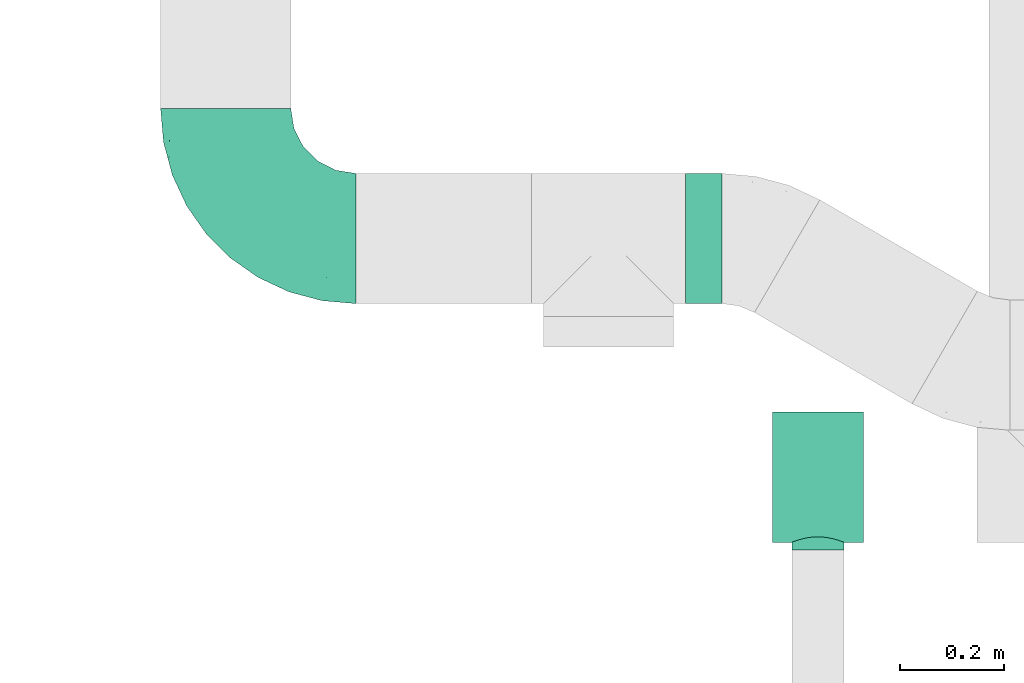
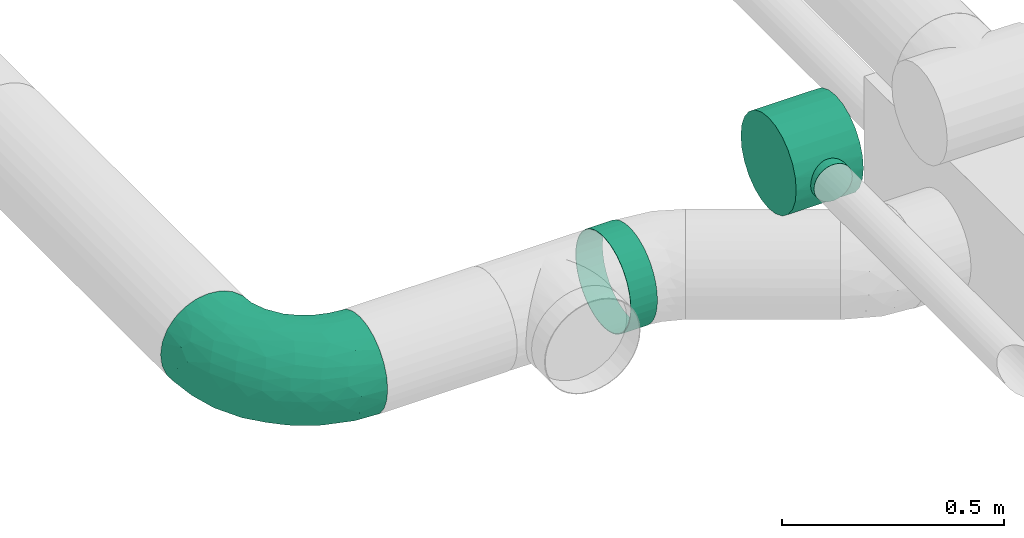
# One storey, part 17 of 91: 2 flow fittings, 1 flow segment.
"""IFC2X3 building model written with IfcOpenShell, lengths in millimetres."""

from ifc_helpers import new_model, entity, si_unit, converted_unit, derived_unit, direction, frame, origin_with_axes, origin_2d_with_axis, place, context, subcontext, project, spatial, hollow_circle, extrude, open_shell, surface_model, source, transform, mapped, material, layer, layer_set, layer_usage, type_object, element, save


model = new_model("IFC2X3")

# Units and contexts
model_context = context("Model", 3, precision=1e-05, world=origin_with_axes(), true_north=direction((0.0, 1.0)))
body_context = subcontext(model_context, "Body", "Model", "MODEL_VIEW")
ifc_project = project(units=[si_unit("AREAUNIT", "SQUARE_METRE"), si_unit("VOLUMEUNIT", "CUBIC_METRE", prefix="DECI"), si_unit("TIMEUNIT", "SECOND"), si_unit("THERMODYNAMICTEMPERATUREUNIT", "DEGREE_CELSIUS"), si_unit("PRESSUREUNIT", "PASCAL"), si_unit("MASSUNIT", "GRAM", prefix="KILO"), si_unit("LENGTHUNIT", "METRE", prefix="MILLI"), si_unit("POWERUNIT", "WATT"), si_unit("ELECTRICCURRENTUNIT", "AMPERE"), si_unit("ELECTRICVOLTAGEUNIT", "VOLT"), derived_unit("VOLUMETRICFLOWRATEUNIT", [(si_unit("VOLUMEUNIT", "CUBIC_METRE", prefix="DECI"), 1), (si_unit("TIMEUNIT", "SECOND"), -1)]), derived_unit("LINEARVELOCITYUNIT", [(si_unit("LENGTHUNIT", "METRE"), 1), (si_unit("TIMEUNIT", "SECOND"), -1)]), derived_unit("MASSDENSITYUNIT", [(si_unit("MASSUNIT", "GRAM", prefix="KILO"), 1), (si_unit("VOLUMEUNIT", "CUBIC_METRE"), -1)]), converted_unit("PLANEANGLEUNIT", "DEGREE", entity("IfcRatioMeasure", 0.01745), si_unit("PLANEANGLEUNIT", "RADIAN"), dimensions=[0, 0, 0, 0, 0, 0, 0])], contexts=[model_context])

# Site, building, storey
site_placement = place(None, origin_with_axes())
site = spatial("IfcSite", under=ifc_project, at=site_placement, CompositionType="ELEMENT")
building_placement = place(site_placement, origin_with_axes())
building = spatial("IfcBuilding", under=site, at=building_placement, Name="mc-building", CompositionType="ELEMENT")
storey_placement = place(building_placement, frame((0.0, 0.0, 8700.0), z_axis=(0.0, 0.0, 1.0), x_axis=(1.0, 0.0, 0.0)))
storey = spatial("IfcBuildingStorey", under=building, at=storey_placement, CompositionType="ELEMENT", Elevation=8700.0)

# Flow fittings
duct_fitting_type_1 = type_object("IfcDuctFittingType", Name="BU", PredefinedType="BEND")
shared_shape_1 = source(origin_with_axes(), body_context, "Body", "SurfaceModel", [
    surface_model("IfcShellBasedSurfaceModel", [(-250.0, 0.0, -125.0), (-250.0, -32.35238, -120.74073), (-250.0, 32.35238, -120.74073), (-250.0, 120.74073, 32.35238), (-250.0, 62.5, -108.25318), (-250.0, 108.25318, -62.5), (-250.0, 88.38835, -88.38835), (-250.0, -125.0, 0.0), (-250.0, -120.74073, 32.35238), (-250.0, -88.38835, -88.38835), (-250.0, -62.5, -108.25318), (-250.0, -120.74073, -32.35238), (-250.0, -108.25318, -62.5), (-250.0, 120.74073, -32.35238), (-250.0, 108.25318, 62.5), (-250.0, 88.38835, 88.38835), (-250.0, 32.35238, 120.74073), (-250.0, 62.5, 108.25318), (-250.0, 0.0, 125.0), (-250.0, -108.25318, 62.5), (-250.0, -88.38835, 88.38835), (-250.0, -32.35238, 120.74073), (-250.0, -62.5, 108.25318), (-250.0, 125.0, 0.0), (-32.35238, 250.0, -120.74073), (-125.0, 250.0, 0.0), (0.0, 250.0, -125.0), (-62.5, 250.0, -108.25318), (-88.38835, 250.0, -88.38835), (-108.25318, 250.0, -62.5), (88.38835, 250.0, -88.38835), (120.74073, 250.0, 32.35238), (62.5, 250.0, -108.25318), (32.35238, 250.0, -120.74073), (108.25318, 250.0, -62.5), (120.74073, 250.0, -32.35238), (125.0, 250.0, 0.0), (-120.74073, 250.0, -32.35238), (-120.74073, 250.0, 32.35238), (-108.25318, 250.0, 62.5), (-88.38835, 250.0, 88.38835), (-32.35238, 250.0, 120.74073), (-62.5, 250.0, 108.25318), (62.5, 250.0, 108.25318), (108.25318, 250.0, 62.5), (88.38835, 250.0, 88.38835), (32.35238, 250.0, 120.74073), (0.0, 250.0, 125.0), (-117.1466, 118.31037, 107.99909), (-96.3976, 96.3976, 120.62713), (-81.83105, 144.33246, 113.94821), (-194.36977, 6.26802, 125.0), (-210.4208, 30.62363, 122.03104), (-141.52906, 24.75778, 125.0), (-170.49386, 38.98103, 122.57548), (-119.6899, 216.62967, 47.83543), (-24.75778, 141.52906, 125.0), (-58.72535, 129.81418, 122.65468), (-54.54213, 94.12755, 125.0), (-164.16498, 126.25836, 75.79028), (-183.25942, 133.03051, 48.20921), (-192.36733, 110.61415, 76.09518), (-129.81418, 58.72535, 122.65468), (-136.01097, 136.01098, 87.97963), (-106.86909, 152.6368, 98.55189), (-123.74113, 163.86567, 78.64582), (-94.12755, 54.54213, 125.0), (-55.07783, 196.37292, 115.48494), (-30.62363, 210.4208, 122.03104), (-80.06444, 213.05689, 99.16916), (-216.62967, 119.68991, 47.83543), (-223.32127, 101.54736, 76.09518), (-226.00176, 125.30303, 22.18937), (-213.05689, 80.06444, 99.16916), (-38.98103, 170.49388, 122.57548), (-167.42296, 153.3147, 23.08194), (-162.69986, 162.69986, 0.0), (-176.52685, 148.87287, 0.0), (-131.11793, 211.37287, 0.0), (-131.91505, 201.08762, 26.37495), (-125.30889, 225.96459, 22.19643), (-196.37292, 55.07783, 115.48495), (-167.53374, 99.7969, 97.1574), (-144.33245, 81.83105, 113.94821), (-82.81251, 177.89548, 104.93319), (-133.0305, 183.25942, 48.20921), (-110.61415, 192.36733, 76.09518), (-101.54736, 223.32127, 76.09518), (-150.35937, 170.37352, 25.11258), (-148.87287, 176.52685, 0.0), (-188.58367, 138.9352, 21.795), (-139.99541, 193.94986, 0.0), (-144.89628, 149.85264, 68.09613), (-6.26802, 194.36977, 125.0), (-155.58398, 155.58398, 45.37002), (-211.37287, 131.11793, 0.0), (-136.01097, 136.01098, -87.97963), (-152.6368, 106.86909, -98.55189), (-163.86567, 123.74113, -78.64581), (-225.96459, 125.30889, -22.19643), (-192.36733, 110.61415, -76.09518), (-223.32127, 101.54736, -76.09518), (-216.62967, 119.68991, -47.83543), (-118.31037, 117.14661, -107.99909), (-170.37352, 150.35937, -25.11258), (-183.25942, 133.03051, -48.20921), (-119.6899, 216.62967, -47.83543), (-133.0305, 183.25942, -48.20921), (-138.9352, 188.58369, -21.795), (-213.05689, 80.06444, -99.16916), (-196.37292, 55.07783, -115.48495), (-201.08762, 131.91505, -26.37495), (-193.94986, 139.99541, 0.0), (-129.81418, 58.72535, -122.65468), (-170.49386, 38.98103, -122.57548), (-144.33245, 81.83105, -113.94821), (-210.4208, 30.62363, -122.03104), (-126.25836, 164.16498, -75.79028), (-99.7969, 167.53376, -97.1574), (-81.83105, 144.33246, -113.94821), (-96.3976, 96.3976, -120.62713), (-55.07783, 196.37292, -115.48494), (-30.62363, 210.4208, -122.03104), (-38.98103, 170.49388, -122.57548), (-177.89548, 82.81251, -104.93319), (-153.3147, 167.42296, -23.08194), (-94.12755, 54.54213, -125.0), (-141.52906, 24.75778, -125.0), (-101.54736, 223.32127, -76.09518), (-80.06444, 213.05689, -99.16916), (-125.30303, 226.00176, -22.18937), (-54.54213, 94.12755, -125.0), (-24.75778, 141.52906, -125.0), (-58.72535, 129.81418, -122.65468), (-110.61415, 192.36733, -76.09518), (-6.26802, 194.36977, -125.0), (-149.85264, 144.89629, -68.09613), (-194.36977, 6.26802, -125.0), (-155.58398, 155.58398, -45.37002), (-193.89957, -74.54276, -96.57977), (-62.5, -74.75953, 0.0), (-121.74244, -102.38473, 0.0), (-94.73344, -89.12736, -22.37394), (119.30291, 184.88194, 0.0), (109.25277, 157.04874, -31.04738), (-53.59476, 53.59477, -121.8788), (-9.37807, 56.98679, -110.48256), (-81.86678, 3.72743, -115.33626), (-145.59015, -7.38807, -121.8788), (-12.03452, 12.03453, -90.20459), (23.00116, 67.52551, -97.38178), (40.98911, 53.20617, -73.25276), (-159.90694, -102.02588, -52.64847), (81.22573, 100.98341, -53.01017), (92.95193, 171.4026, -72.47744), (107.80964, 186.67175, -52.65074), (13.81192, -13.81192, -21.78849), (8.88806, -8.88806, -46.26498), (55.09242, 37.49634, -28.07964), (-184.88194, -119.30291, 0.0), (87.32054, 94.83884, -30.20715), (49.0818, 42.5299, -51.28061), (-171.40262, -92.95193, -72.47744), (-3.30282, -3.44047, -69.82022), (-100.98341, -81.22573, -53.01016), (37.26667, 8.95465, 0.0), (-8.95465, -37.26667, 0.0), (-37.49634, -55.09242, -28.07964), (46.65178, 188.51647, -113.22824), (-157.04874, -109.25277, -31.04738), (16.88787, 136.38295, -118.40506), (-42.32523, -45.52951, -57.0897), (-69.83191, -18.55522, -101.18597), (-150.46416, -40.11916, -111.39103), (-60.46923, -37.78604, -81.71663), (74.54276, 193.89959, -96.57977), (102.38473, 121.74244, 0.0), (74.75953, 62.5, 0.0), (36.31281, 122.56516, -107.73314), (-124.37151, -58.88278, -93.06207), (-111.05914, -71.02736, -75.26007), (71.09889, 111.35886, -75.33067), (58.88278, 124.37151, -93.06207), (-157.04874, -109.25277, 31.04738), (-53.20616, -40.9891, 73.25276), (3.44048, 3.30283, 69.82022), (-12.03452, 12.03453, 90.20459), (55.09242, 37.49634, 28.07964), (-37.49634, -55.09242, 28.07964), (-94.83884, -87.32054, 30.20715), (-67.52551, -23.00116, 97.38178), (-186.67175, -107.80965, 52.65074), (7.38807, 145.59015, 121.8788), (-42.5299, -49.0818, 51.28061), (-53.59476, 53.59477, 121.8788), (-56.98679, 9.37808, 110.48256), (-3.72743, 81.86679, 115.33626), (13.81192, -13.81192, 21.78849), (-188.51647, -46.65178, 113.22824), (-136.38295, -16.88787, 118.40506), (-171.40262, -92.95193, 72.47744), (40.11916, 150.46417, 111.39103), (-122.56517, -36.31281, 107.73314), (92.95193, 171.4026, 72.47744), (37.78605, 60.46924, 81.71663), (-193.89957, -74.54276, 96.57977), (8.88806, -8.88806, 46.26498), (109.25277, 157.04874, 31.04738), (89.12736, 94.73344, 22.37394), (18.55523, 69.83191, 101.18597), (-100.98341, -81.22573, 53.01016), (102.02588, 159.90694, 52.64847), (81.22573, 100.98341, 53.01017), (74.54276, 193.89959, 96.57977), (45.52951, 42.32523, 57.0897), (58.88278, 124.37151, 93.06207), (-111.35886, -71.09889, 75.33067), (-124.37151, -58.88278, 93.06207), (71.02736, 111.05915, 75.26008)], [open_shell([[[0, 1, 2]], [[2, 3, 4]], [[5, 6, 3]], [[3, 6, 4]], [[2, 7, 8]], [[9, 7, 10]], [[2, 1, 10]], [[11, 7, 12]], [[9, 12, 7]], [[10, 7, 2]], [[13, 5, 3]], [[14, 3, 2]], [[14, 2, 15]], [[2, 16, 17]], [[17, 15, 2]], [[16, 2, 18]], [[19, 20, 2]], [[2, 8, 19]], [[21, 18, 22]], [[20, 22, 18]], [[18, 2, 20]], [[23, 13, 3]], [[24, 25, 26]], [[27, 25, 24]], [[25, 28, 29]], [[27, 28, 25]], [[30, 26, 31]], [[26, 30, 32]], [[32, 33, 26]], [[30, 31, 34]], [[35, 34, 31]], [[35, 31, 36]], [[37, 25, 29]], [[38, 39, 26]], [[39, 40, 26]], [[41, 26, 42]], [[26, 40, 42]], [[43, 26, 41]], [[44, 31, 26]], [[45, 44, 26]], [[41, 46, 43]], [[45, 26, 43]], [[46, 41, 47]], [[38, 26, 25]], [[48, 49, 50]], [[18, 51, 52]], [[51, 53, 54]], [[39, 38, 55]], [[56, 57, 58]], [[59, 60, 61]], [[57, 49, 58]], [[54, 53, 62]], [[63, 64, 65]], [[62, 53, 66]], [[67, 68, 41]], [[42, 40, 69]], [[70, 14, 71]], [[3, 72, 23]], [[70, 3, 14]], [[73, 15, 17]], [[57, 74, 50]], [[14, 15, 71]], [[75, 76, 77]], [[42, 69, 67]], [[58, 49, 66]], [[78, 79, 80]], [[16, 81, 17]], [[82, 73, 81]], [[74, 68, 67]], [[49, 48, 83]], [[81, 52, 54]], [[42, 67, 41]], [[41, 68, 47]], [[60, 70, 61]], [[72, 3, 70]], [[84, 67, 69]], [[85, 86, 55]], [[87, 40, 39]], [[88, 89, 76]], [[64, 63, 48]], [[59, 82, 63]], [[17, 81, 73]], [[25, 78, 80]], [[86, 87, 55]], [[70, 60, 90]], [[62, 49, 83]], [[82, 81, 83]], [[60, 75, 90]], [[71, 73, 61]], [[79, 91, 88]], [[87, 69, 40]], [[86, 64, 84]], [[92, 59, 63]], [[76, 75, 88]], [[78, 91, 79]], [[65, 92, 63]], [[49, 62, 66]], [[54, 83, 81]], [[83, 54, 62]], [[81, 16, 52]], [[74, 57, 56]], [[49, 57, 50]], [[93, 74, 56]], [[50, 74, 67]], [[18, 52, 16]], [[51, 54, 52]], [[74, 93, 68]], [[47, 68, 93]], [[73, 71, 15]], [[70, 71, 61]], [[55, 87, 39]], [[69, 87, 86]], [[64, 48, 50]], [[48, 63, 82]], [[84, 64, 50]], [[65, 64, 86]], [[67, 84, 50]], [[86, 84, 69]], [[86, 85, 65]], [[92, 85, 94]], [[85, 92, 65]], [[59, 94, 60]], [[59, 92, 94]], [[82, 59, 61]], [[73, 82, 61]], [[82, 83, 48]], [[94, 88, 75]], [[90, 75, 77]], [[60, 94, 75]], [[77, 95, 90]], [[90, 95, 72]], [[94, 85, 88]], [[88, 91, 89]], [[79, 88, 85]], [[85, 55, 79]], [[80, 79, 55]], [[55, 38, 80]], [[25, 80, 38]], [[90, 72, 70]], [[23, 72, 95]], [[96, 97, 98]], [[23, 95, 99]], [[100, 101, 102]], [[97, 96, 103]], [[104, 77, 76]], [[100, 102, 105]], [[5, 13, 102]], [[101, 6, 5]], [[106, 107, 108]], [[4, 109, 110]], [[111, 112, 104]], [[113, 114, 115]], [[4, 110, 2]], [[2, 116, 0]], [[117, 118, 96]], [[114, 116, 110]], [[103, 119, 120]], [[121, 122, 123]], [[110, 109, 124]], [[125, 76, 89]], [[126, 127, 113]], [[100, 97, 124]], [[128, 29, 28]], [[4, 6, 109]], [[29, 106, 37]], [[129, 28, 27]], [[24, 121, 27]], [[106, 29, 128]], [[37, 130, 25]], [[110, 116, 2]], [[95, 111, 99]], [[118, 129, 121]], [[27, 121, 129]], [[126, 120, 131]], [[123, 132, 133]], [[125, 108, 107]], [[117, 107, 134]], [[103, 120, 115]], [[26, 135, 122]], [[135, 132, 123]], [[132, 131, 133]], [[113, 120, 126]], [[130, 37, 106]], [[133, 120, 119]], [[101, 109, 6]], [[107, 106, 134]], [[118, 121, 119]], [[128, 129, 134]], [[95, 112, 111]], [[98, 136, 96]], [[136, 117, 96]], [[76, 125, 104]], [[114, 113, 127]], [[120, 113, 115]], [[137, 114, 127]], [[115, 114, 110]], [[120, 133, 131]], [[123, 119, 121]], [[119, 123, 133]], [[121, 24, 122]], [[114, 137, 116]], [[0, 116, 137]], [[26, 122, 24]], [[135, 123, 122]], [[102, 101, 5]], [[109, 101, 100]], [[129, 128, 28]], [[106, 128, 134]], [[97, 103, 115]], [[103, 96, 118]], [[124, 97, 115]], [[98, 97, 100]], [[110, 124, 115]], [[100, 124, 109]], [[100, 105, 98]], [[136, 105, 138]], [[105, 136, 98]], [[117, 138, 107]], [[117, 136, 138]], [[118, 117, 134]], [[129, 118, 134]], [[118, 119, 103]], [[138, 104, 125]], [[108, 125, 89]], [[107, 138, 125]], [[89, 78, 108]], [[108, 78, 130]], [[138, 105, 104]], [[104, 112, 77]], [[111, 104, 105]], [[105, 102, 111]], [[99, 111, 102]], [[102, 13, 99]], [[23, 99, 13]], [[108, 130, 106]], [[25, 130, 78]], [[139, 9, 10]], [[140, 141, 142]], [[35, 143, 144]], [[127, 126, 145]], [[126, 131, 145]], [[145, 146, 147]], [[137, 148, 0]], [[149, 150, 151]], [[127, 145, 148]], [[152, 11, 12]], [[153, 154, 155]], [[156, 157, 158]], [[159, 7, 11]], [[144, 160, 153]], [[161, 158, 157]], [[152, 12, 162]], [[151, 161, 163]], [[152, 162, 164]], [[156, 165, 166]], [[142, 164, 167]], [[168, 33, 32]], [[141, 159, 169]], [[142, 141, 169]], [[127, 148, 137]], [[132, 170, 145]], [[171, 167, 164]], [[135, 170, 132]], [[0, 148, 1]], [[147, 172, 173]], [[170, 135, 33]], [[168, 170, 33]], [[132, 145, 131]], [[173, 148, 147]], [[1, 148, 173]], [[149, 163, 174]], [[33, 135, 26]], [[146, 145, 170]], [[34, 155, 154]], [[30, 175, 32]], [[156, 166, 167]], [[160, 176, 177]], [[149, 174, 172]], [[160, 177, 158]], [[154, 30, 34]], [[162, 12, 9]], [[36, 143, 35]], [[165, 158, 177]], [[144, 143, 176]], [[35, 144, 155]], [[140, 167, 166]], [[146, 178, 150]], [[147, 148, 145]], [[159, 11, 169]], [[151, 163, 149]], [[178, 170, 168]], [[172, 146, 149]], [[139, 173, 179]], [[1, 173, 10]], [[139, 162, 9]], [[180, 179, 174]], [[181, 153, 151]], [[175, 154, 182]], [[175, 168, 32]], [[168, 175, 178]], [[150, 178, 182]], [[146, 170, 178]], [[182, 154, 181]], [[146, 150, 149]], [[182, 151, 150]], [[153, 160, 161]], [[157, 156, 167]], [[165, 156, 158]], [[157, 171, 163]], [[174, 179, 172]], [[171, 174, 163]], [[179, 180, 162]], [[173, 172, 179]], [[146, 172, 147]], [[167, 171, 157]], [[171, 164, 180]], [[171, 180, 174]], [[164, 162, 180]], [[154, 175, 30]], [[175, 182, 178]], [[173, 139, 10]], [[162, 139, 179]], [[164, 142, 169]], [[140, 142, 167]], [[163, 161, 157]], [[151, 153, 161]], [[176, 160, 144]], [[161, 160, 158]], [[164, 169, 152]], [[152, 169, 11]], [[35, 155, 34]], [[153, 155, 144]], [[153, 181, 154]], [[151, 182, 181]], [[183, 159, 141]], [[159, 8, 7]], [[184, 185, 186]], [[187, 165, 177]], [[140, 188, 189]], [[186, 190, 184]], [[183, 191, 8]], [[56, 192, 93]], [[185, 184, 193]], [[189, 141, 140]], [[194, 195, 196]], [[197, 188, 166]], [[198, 199, 21]], [[191, 200, 19]], [[46, 192, 201]], [[195, 202, 190]], [[203, 44, 45]], [[51, 18, 21]], [[198, 21, 22]], [[199, 53, 51]], [[21, 199, 51]], [[53, 194, 66]], [[196, 192, 194]], [[186, 185, 204]], [[166, 188, 140]], [[200, 20, 19]], [[205, 22, 20]], [[188, 197, 206]], [[176, 143, 207]], [[208, 176, 207]], [[143, 36, 31]], [[186, 204, 209]], [[183, 189, 210]], [[203, 211, 44]], [[177, 176, 208]], [[187, 208, 212]], [[187, 197, 165]], [[212, 211, 203]], [[58, 192, 56]], [[194, 58, 66]], [[47, 192, 46]], [[196, 209, 201]], [[211, 31, 44]], [[194, 192, 58]], [[8, 159, 183]], [[93, 192, 47]], [[143, 31, 207]], [[194, 53, 199]], [[45, 43, 213]], [[210, 200, 191]], [[193, 188, 206]], [[196, 201, 192]], [[214, 187, 212]], [[195, 194, 199]], [[202, 199, 198]], [[209, 195, 186]], [[213, 201, 215]], [[46, 201, 43]], [[216, 210, 184]], [[205, 200, 217]], [[213, 203, 45]], [[218, 215, 204]], [[205, 198, 22]], [[198, 205, 202]], [[190, 202, 217]], [[195, 199, 202]], [[217, 200, 216]], [[195, 190, 186]], [[217, 184, 190]], [[210, 189, 193]], [[165, 197, 166]], [[206, 197, 187]], [[206, 214, 185]], [[204, 215, 209]], [[214, 204, 185]], [[215, 218, 203]], [[201, 209, 215]], [[195, 209, 196]], [[187, 214, 206]], [[214, 212, 218]], [[214, 218, 204]], [[212, 203, 218]], [[200, 205, 20]], [[205, 217, 202]], [[201, 213, 43]], [[203, 213, 215]], [[185, 193, 206]], [[184, 210, 193]], [[141, 189, 183]], [[193, 189, 188]], [[212, 208, 207]], [[177, 208, 187]], [[8, 191, 19]], [[210, 191, 183]], [[212, 207, 211]], [[211, 207, 31]], [[210, 216, 200]], [[184, 217, 216]]])]),
])
flow_fitting_1_placement = place(storey_placement, frame((6828.023, 8133.41275, 668.0), z_axis=(0.0, 0.0, 1.0), x_axis=(0.0, -1.0, 0.0)))
element("IfcFlowFitting", 1, at=flow_fitting_1_placement, inside=storey, type_object=duct_fitting_type_1, Name="BU", context=body_context, shape_type="MappedRepresentation", body=[
    mapped(shared_shape_1, transform((0.0, 0.0, 0.0), scale=1.0)),
])
duct_fitting_type_2 = type_object("IfcDuctFittingType", PredefinedType="JUNCTION")
shared_shape_2 = source(origin_with_axes(), body_context, "Body", "SurfaceModel", [
    surface_model("IfcShellBasedSurfaceModel", [(0.0, -140.0, -50.0), (12.94095, -140.0, -48.29629), (-12.94095, -140.0, -48.29629), (-48.29629, -140.0, 12.94095), (-25.0, -140.0, -43.30127), (-35.35534, -140.0, -35.35534), (-43.30127, -140.0, -25.0), (50.0, -140.0, 0.0), (48.29629, -140.0, 12.94095), (35.35534, -140.0, -35.35534), (25.0, -140.0, -43.30127), (48.29629, -140.0, -12.94095), (43.30127, -140.0, -25.0), (-48.29629, -140.0, -12.94095), (-43.30127, -140.0, 25.0), (-35.35534, -140.0, 35.35534), (-25.0, -140.0, 43.30127), (12.94095, -140.0, 48.29629), (-12.94095, -140.0, 48.29629), (43.30127, -140.0, 25.0), (35.35534, -140.0, 35.35534), (25.0, -140.0, 43.30127), (0.0, -140.0, 50.0), (-50.0, -140.0, 0.0), (0.0, -114.56439, 50.0), (-11.23344, -115.11381, 48.72176), (-21.81227, -116.62236, 44.99139), (-31.21528, -118.74087, 39.05901), (-39.0526, -121.03762, 31.2233), (-44.99266, -123.08265, 21.80964), (-48.72466, -124.49535, 11.22084), (-50.0, -125.0, 0.0), (-44.98471, -123.07975, -21.82604), (-39.04056, -121.03374, -31.23835), (-48.72121, -124.494, -11.23581), (-31.2003, -118.73693, -39.07098), (-21.79611, -116.61934, -44.99922), (-11.21877, -115.11239, -48.72514), (0.0, -114.56439, -50.0), (11.23344, -115.11381, -48.72176), (21.81227, -116.62236, -44.99139), (31.21528, -118.74087, -39.05901), (39.0526, -121.03762, -31.2233), (44.99266, -123.08265, -21.80964), (48.72466, -124.49535, -11.22084), (50.0, -125.0, 0.0), (44.99266, -123.08265, 21.80964), (39.0526, -121.03762, 31.2233), (48.72466, -124.49535, 11.22084), (31.21528, -118.74087, 39.05901), (21.81227, -116.62236, 44.99139), (11.23344, -115.11381, 48.72176), (-87.5, 0.0, -125.0), (-87.5, -32.35238, -120.74073), (-87.5, 32.35238, -120.74073), (-87.5, 120.74073, 32.35238), (-87.5, 62.5, -108.25318), (-87.5, 88.38835, -88.38835), (-87.5, 108.25318, -62.5), (-87.5, -125.0, 0.0), (-87.5, -120.74073, 32.35238), (-87.5, -88.38835, -88.38835), (-87.5, -62.5, -108.25318), (-87.5, -120.74073, -32.35238), (-87.5, -108.25318, -62.5), (-87.5, 120.74073, -32.35238), (-87.5, 108.25318, 62.5), (-87.5, 62.5, 108.25318), (-87.5, 32.35238, 120.74073), (-87.5, 88.38835, 88.38835), (-87.5, 0.0, 125.0), (-87.5, -108.25318, 62.5), (-87.5, -88.38835, 88.38835), (-87.5, -32.35238, 120.74073), (-87.5, -62.5, 108.25318), (-87.5, 125.0, 0.0), (87.5, 32.35238, -120.74073), (87.5, 125.0, 0.0), (87.5, 0.0, -125.0), (87.5, 62.5, -108.25318), (87.5, 108.25318, -62.5), (87.5, 88.38835, -88.38835), (87.5, -88.38835, -88.38835), (87.5, -120.74073, 32.35238), (87.5, -62.5, -108.25318), (87.5, -32.35238, -120.74073), (87.5, -108.25318, -62.5), (87.5, -120.74073, -32.35238), (87.5, -125.0, 0.0), (87.5, 120.74073, -32.35238), (87.5, 120.74073, 32.35238), (87.5, 108.25318, 62.5), (87.5, 62.5, 108.25318), (87.5, 32.35238, 120.74073), (87.5, 88.38835, 88.38835), (87.5, -62.5, 108.25318), (87.5, -108.25318, 62.5), (87.5, -88.38835, 88.38835), (87.5, -32.35238, 120.74073), (87.5, 0.0, 125.0), (-87.5, -122.87036, -16.17619), (87.5, -122.87036, -16.17619), (87.5, -122.87036, 16.17619), (-87.5, -122.87036, 16.17619)], [open_shell([[[0, 1, 2]], [[2, 3, 4]], [[5, 3, 6]], [[4, 3, 5]], [[2, 7, 8]], [[9, 7, 10]], [[1, 10, 7]], [[11, 7, 12]], [[9, 12, 7]], [[7, 2, 1]], [[13, 6, 3]], [[14, 3, 2]], [[15, 14, 2]], [[16, 2, 17]], [[16, 15, 2]], [[16, 17, 18]], [[2, 8, 19]], [[2, 19, 20]], [[20, 21, 2]], [[17, 2, 21]], [[17, 22, 18]], [[23, 13, 3]], [[22, 24, 25]], [[18, 25, 26]], [[22, 25, 18]], [[16, 27, 15]], [[16, 18, 26]], [[27, 16, 26]], [[28, 29, 14]], [[30, 31, 23]], [[29, 30, 3]], [[15, 28, 14]], [[3, 14, 29]], [[23, 3, 30]], [[28, 15, 27]], [[32, 33, 6]], [[34, 32, 13]], [[31, 34, 23]], [[23, 34, 13]], [[32, 6, 13]], [[33, 5, 6]], [[4, 35, 36]], [[36, 37, 2]], [[38, 0, 37]], [[5, 35, 4]], [[0, 2, 37]], [[36, 2, 4]], [[35, 5, 33]], [[0, 38, 39]], [[1, 39, 40]], [[0, 39, 1]], [[10, 41, 9]], [[10, 1, 40]], [[41, 10, 40]], [[42, 43, 12]], [[44, 45, 7]], [[43, 44, 11]], [[9, 42, 12]], [[11, 12, 43]], [[7, 11, 44]], [[42, 9, 41]], [[46, 47, 19]], [[48, 46, 8]], [[45, 48, 7]], [[7, 48, 8]], [[46, 19, 8]], [[47, 20, 19]], [[21, 49, 50]], [[50, 51, 17]], [[24, 22, 51]], [[20, 49, 21]], [[17, 21, 50]], [[22, 17, 51]], [[49, 20, 47]], [[52, 53, 54]], [[54, 55, 56]], [[57, 55, 58]], [[56, 55, 57]], [[54, 59, 60]], [[61, 59, 62]], [[54, 53, 62]], [[63, 59, 64]], [[61, 64, 59]], [[62, 59, 54]], [[65, 58, 55]], [[66, 55, 54]], [[67, 66, 54]], [[67, 54, 68]], [[69, 66, 67]], [[70, 68, 54]], [[60, 71, 54]], [[71, 72, 54]], [[73, 70, 74]], [[72, 74, 70]], [[54, 72, 70]], [[75, 65, 55]], [[76, 77, 78]], [[79, 77, 76]], [[80, 77, 81]], [[79, 81, 77]], [[82, 78, 83]], [[78, 84, 85]], [[78, 82, 84]], [[86, 83, 87]], [[86, 82, 83]], [[83, 88, 87]], [[77, 80, 89]], [[90, 91, 78]], [[78, 91, 92]], [[93, 78, 92]], [[92, 91, 94]], [[78, 93, 95]], [[78, 96, 83]], [[97, 96, 78]], [[97, 78, 95]], [[93, 98, 95]], [[93, 99, 98]], [[77, 90, 78]], [[68, 99, 93]], [[67, 93, 92]], [[70, 99, 68]], [[68, 93, 67]], [[92, 69, 67]], [[92, 94, 69]], [[55, 91, 90]], [[75, 90, 77]], [[94, 66, 69]], [[94, 91, 66]], [[66, 91, 55]], [[90, 75, 55]], [[89, 80, 65]], [[77, 89, 75]], [[65, 75, 89]], [[58, 65, 80]], [[80, 57, 58]], [[80, 81, 57]], [[54, 79, 76]], [[52, 76, 78]], [[81, 56, 57]], [[81, 79, 56]], [[56, 79, 54]], [[76, 52, 54]], [[85, 53, 78]], [[84, 62, 85]], [[64, 82, 86]], [[34, 59, 100]], [[39, 38, 86]], [[86, 40, 39]], [[84, 82, 61]], [[64, 86, 38]], [[85, 62, 53]], [[53, 52, 78]], [[37, 36, 64]], [[43, 101, 44]], [[61, 82, 64]], [[36, 63, 64]], [[61, 62, 84]], [[38, 37, 64]], [[41, 87, 42]], [[87, 41, 40]], [[42, 87, 43]], [[88, 45, 44]], [[87, 101, 43]], [[44, 101, 88]], [[63, 33, 32]], [[33, 63, 35]], [[35, 63, 36]], [[100, 63, 32]], [[31, 59, 34]], [[100, 32, 34]], [[87, 40, 86]], [[45, 88, 48]], [[102, 83, 46]], [[46, 83, 47]], [[46, 48, 102]], [[49, 47, 83]], [[83, 50, 49]], [[31, 30, 59]], [[59, 30, 103]], [[28, 27, 60]], [[60, 103, 29]], [[60, 29, 28]], [[27, 26, 60]], [[50, 96, 51]], [[96, 50, 83]], [[24, 51, 96]], [[48, 88, 102]], [[95, 98, 73]], [[74, 97, 95]], [[72, 96, 97]], [[70, 98, 99]], [[25, 24, 71]], [[26, 71, 60]], [[71, 26, 25]], [[96, 71, 24]], [[29, 103, 30]], [[96, 72, 71]], [[97, 74, 72]], [[73, 74, 95]], [[98, 70, 73]]])]),
])
flow_fitting_2_placement = place(storey_placement, frame((7965.12654, 7675.18604, 1214.30701), z_axis=(0.0, 0.0, 1.0), x_axis=(1.0, 0.0, 0.0)))
element("IfcFlowFitting", 2, at=flow_fitting_2_placement, inside=storey, type_object=duct_fitting_type_2, context=body_context, shape_type="MappedRepresentation", body=[
    mapped(shared_shape_2, transform((0.0, 0.0, 0.0), scale=1.0)),
])

# Flow segment
ifc_material = material(Name="FZ1")
ifc_layer = layer(ifc_material, 0.0)
ifc_layer_set = layer_set([ifc_layer], Name="FZ1")
ifc_layer_usage = layer_usage(ifc_layer_set, "AXIS1", "POSITIVE", 0.0)
duct_segment_type = type_object("IfcDuctSegmentType", Name="Safe", PredefinedType="RIGIDSEGMENT")
shared_shape_3 = source(origin_with_axes(), body_context, "Body", "SweptSolid", [
    extrude(hollow_circle(Radius=125.0, WallThickness=2.0, at=origin_2d_with_axis()), frame((0.0, 0.0, 0.0), z_axis=(1.0, 0.0, 0.0), x_axis=(0.0, 1.0, 0.0)), (0.0, 0.0, 1.0), 69.4),
])
flow_segment_placement = place(storey_placement, frame((7711.36286, 8133.41275, 668.0), z_axis=(0.0, 0.0, 1.0), x_axis=(1.0, 0.0, 0.0)))
element("IfcFlowSegment", 3, at=flow_segment_placement, inside=storey, type_object=duct_segment_type, material=ifc_layer_usage, Name="Safe", context=body_context, shape_type="MappedRepresentation", body=[
    mapped(shared_shape_3, transform((0.0, 0.0, 0.0), scale=1.0)),
])

save(model, "model.ifc")
